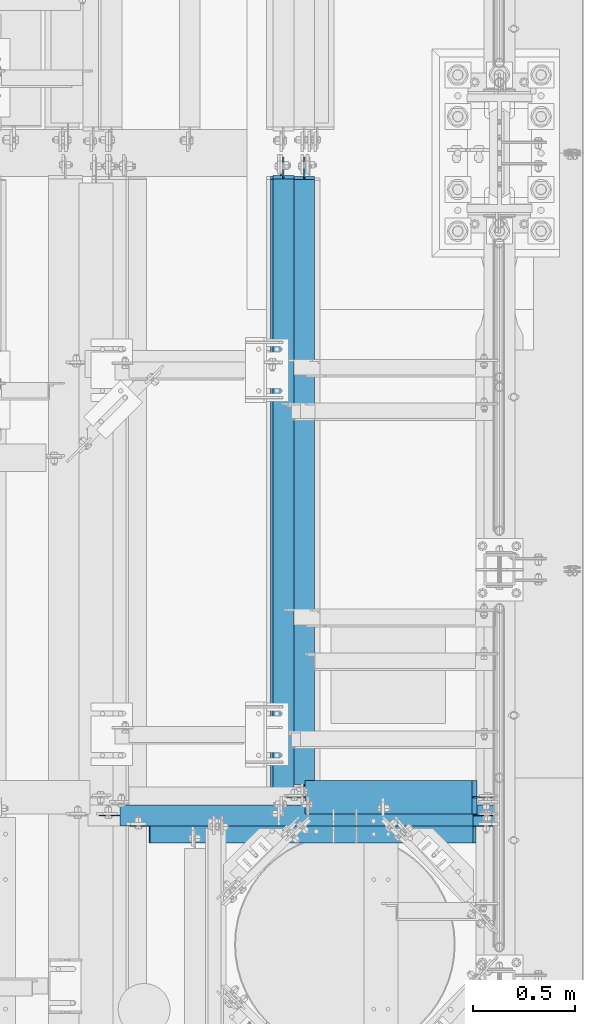
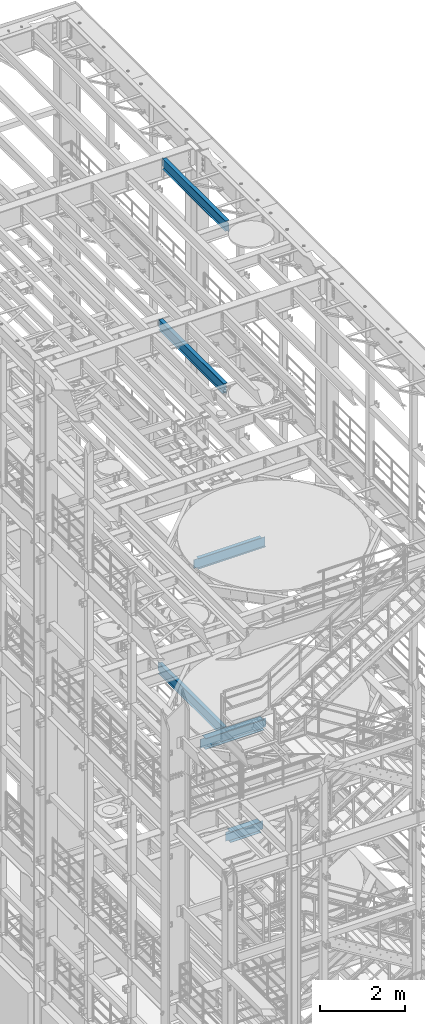
# One storey, part 1033 of 1876: 6 beams, 6 elements without a shape of their own.
"""IFC2X3 building model written with IfcOpenShell, lengths in millimetres."""

from ifc_helpers import new_model, si_unit, frame, origin_with_axes, place, context, subcontext, project, spatial, faceted_brep, material, type_object, element, aggregate, save


model = new_model("IFC2X3")

# Units and contexts
model_context = context("Model", 3, precision=1e-05, world=origin_with_axes())
body_context = subcontext(model_context, "Body", "Model", "MODEL_VIEW")
ifc_project = project(units=[si_unit("LENGTHUNIT", "METRE", prefix="MILLI"), si_unit("AREAUNIT", "SQUARE_METRE"), si_unit("VOLUMEUNIT", "CUBIC_METRE"), si_unit("MASSUNIT", "GRAM", prefix="KILO"), si_unit("TIMEUNIT", "SECOND"), si_unit("PLANEANGLEUNIT", "RADIAN"), si_unit("SOLIDANGLEUNIT", "STERADIAN"), si_unit("THERMODYNAMICTEMPERATUREUNIT", "DEGREE_CELSIUS"), si_unit("LUMINOUSINTENSITYUNIT", "LUMEN")], contexts=[model_context])

# Site, building, storey
site_placement = place(None, origin_with_axes())
site = spatial("IfcSite", under=ifc_project, at=site_placement, CompositionType="ELEMENT")
building_placement = place(site_placement, origin_with_axes())
building = spatial("IfcBuilding", under=site, at=building_placement, Name="Undefined", CompositionType="ELEMENT")
storey_placement = place(building_placement, origin_with_axes())
storey = spatial("IfcBuildingStorey", under=building, at=storey_placement, Name="Undefined", CompositionType="ELEMENT", Elevation=0.0)

# Assembly, beam
assembly_1_placement = place(storey_placement, origin_with_axes())
assembly_1 = element("IfcElementAssembly", 1, at=assembly_1_placement, inside=storey, Name="BEAM", AssemblyPlace="NOTDEFINED", PredefinedType="RIGID_FRAME")
ifc_material = material(Name="STEEL/A992")
beam_type_1 = type_object("IfcBeamType", Name="W12X26", PredefinedType="NOTDEFINED")
beam_1_placement = place(assembly_1_placement, frame((6565.9, 4476.75, 4975.225), z_axis=(0.0, 0.0, 1.0), x_axis=(1.0, 0.0, 0.0)))
beam_1 = element("IfcBeam", 2, at=beam_1_placement, type_object=beam_type_1, material=ifc_material, Name="BEAM", ObjectType="W12X26", context=body_context, shape_type="Brep", body=[
    faceted_brep([(945.356250000002, -3.17500000000018, -146.05), (945.356250000002, -82.5500000000002, -146.05), (945.356250000002, -82.5500000000002, -155.575), (945.356250000002, 82.5500000000002, -155.575), (945.356250000002, 82.5500000000002, -146.05), (945.356250000002, 3.17500000000018, -146.05), (945.356250000002, 3.17500000000018, -142.874999809265), (945.356250000002, -3.17500000000018, -142.874999809265), (946.322979922589, 3.17500000000018, -138.01492029122), (946.322979922589, -3.17500000000018, -138.01492029122), (949.075993823068, 3.17500000000018, -133.894743823066), (949.075993823068, -3.17500000000018, -133.894743823066), (953.196170291221, 3.17500000000018, -131.141729922588), (953.196170291221, -3.17500000000018, -131.141729922588), (958.056249809267, 3.17500000000018, -130.175), (958.056249809267, -3.17500000000018, -130.175), (1034.25625, -3.17500000000018, -130.175), (1034.25625, 3.17500000000018, -130.175), (104.774999999999, 3.17499999999927, 146.05), (104.774999999999, 82.5499999999993, 146.05), (919.956250000002, 82.5500000000002, 146.05), (919.956250000002, 3.17500000000018, 146.05), (104.775000000001, -3.17500000000018, -142.874999809264), (104.775000000001, 3.17500000000018, -142.874999809264), (104.774999924721, 3.17500000000018, -146.049999999999), (104.775000000001, 82.5500000000002, -146.05), (104.775000000001, 82.5500000000002, -155.575), (104.775000000001, -82.5500000000002, -155.575), (104.775000000001, -82.5500000000002, -146.05), (104.774999924721, -3.17500000000018, -146.049999999999), (103.808270077414, -3.17500000000018, -138.014920291219), (103.808270077414, 3.17500000000018, -138.014920291219), (101.055256176935, -3.17500000000018, -133.894743823065), (101.055256176935, 3.17500000000018, -133.894743823065), (96.9350797087818, -3.17500000000018, -131.141729922587), (96.9350797087818, 3.17500000000018, -131.141729922587), (92.0750001907363, -3.17500000000018, -130.174999999999), (92.0750001907363, 3.17500000000018, -130.174999999999), (15.875, -3.17500000000018, -130.175000000003), (15.875, 3.17500000000018, -130.175000000003), (15.8750000000018, -3.17500000000018, 130.175000000001), (15.8750000000018, 3.17500000000018, 130.175000000001), (92.0750001907363, -3.17500000000018, 130.175000000001), (92.0750001907363, 3.17500000000018, 130.175000000001), (96.9350797087818, -3.17500000000018, 131.141729922589), (96.9350797087818, 3.17500000000018, 131.141729922589), (101.055256176935, -3.17500000000018, 133.894743823067), (101.055256176935, 3.17500000000018, 133.894743823067), (103.808270077414, -3.17500000000018, 138.014920291221), (103.808270077414, 3.17500000000018, 138.014920291221), (104.775000000001, -3.17500000000018, 142.874999809266), (104.775000000001, 3.17500000000018, 142.874999809266), (104.774999999999, -82.5499999999993, 155.575), (104.774999999999, 82.5499999999993, 155.575), (104.774999999999, -3.17499999999927, 146.05), (104.774999999999, -82.5499999999993, 146.05), (919.956250000002, -3.17500000000018, 146.05), (919.956250000002, -82.5500000000002, 146.05), (919.956250000002, -82.5500000000002, 155.575), (919.956250000002, 82.5500000000002, 155.575), (919.956250000002, -3.17500000000018, 130.174999809265), (919.956250000002, 3.17500000000018, 130.174999809265), (920.92297992259, -3.17500000000018, 125.314920291219), (920.92297992259, 3.17500000000018, 125.314920291219), (923.675993823068, -3.17500000000018, 121.194743823065), (923.675993823068, 3.17500000000018, 121.194743823065), (927.796170291222, -3.17500000000018, 118.441729922587), (927.796170291222, 3.17500000000018, 118.441729922587), (932.656249809267, -3.17500000000018, 117.474999999999), (932.656249809267, 3.17500000000018, 117.474999999999), (1034.25625, -3.17500000000018, 117.474999999999), (1034.25625, 3.17500000000018, 117.474999999999)], [[[0, 1, 2, 3, 4, 5, 6, 7]], [[7, 6, 8, 9]], [[9, 8, 10, 11]], [[11, 10, 12, 13]], [[13, 12, 14, 15]], [[16, 15, 14, 17]], [[18, 19, 20, 21]], [[22, 23, 24, 25, 26, 27, 28, 29]], [[30, 31, 23, 22]], [[32, 33, 31, 30]], [[34, 35, 33, 32]], [[36, 37, 35, 34]], [[38, 39, 37, 36]], [[40, 41, 39, 38]], [[42, 43, 41, 40]], [[44, 45, 43, 42]], [[46, 47, 45, 44]], [[48, 49, 47, 46]], [[50, 51, 49, 48]], [[52, 53, 19, 18, 51, 50, 54, 55]], [[55, 54, 56, 57]], [[52, 55, 57, 58]], [[53, 52, 58, 59]], [[19, 53, 59, 20]], [[58, 57, 56, 60, 61, 21, 20, 59]], [[62, 63, 61, 60]], [[64, 65, 63, 62]], [[66, 67, 65, 64]], [[68, 69, 67, 66]], [[70, 71, 69, 68]], [[71, 70, 16, 17]], [[12, 10, 8, 6, 5, 24, 23, 31, 33, 35, 37, 39, 41, 43, 45, 47, 49, 51, 18, 21, 61, 63, 65, 67, 69, 71, 17, 14]], [[25, 24, 5, 4]], [[26, 25, 4, 3]], [[27, 26, 3, 2]], [[28, 27, 2, 1]], [[29, 28, 1, 0]], [[70, 68, 66, 64, 62, 60, 56, 54, 50, 48, 46, 44, 42, 40, 38, 36, 34, 32, 30, 22, 29, 0, 7, 9, 11, 13, 15, 16]]]),
])
aggregate(assembly_1, [beam_1])

assembly_2_placement = place(storey_placement, origin_with_axes())
assembly_2 = element("IfcElementAssembly", 3, at=assembly_2_placement, inside=storey, Name="BEAM", AssemblyPlace="NOTDEFINED", PredefinedType="RIGID_FRAME")
beam_type_2 = type_object("IfcBeamType", Name="W12X16", PredefinedType="NOTDEFINED")
beam_2_placement = place(assembly_2_placement, frame((6667.5, 4444.99920043945, 22402.8), z_axis=(0.0, 0.0, 1.0), x_axis=(0.0, 1.0, 0.0)))
beam_2 = element("IfcBeam", 4, at=beam_2_placement, type_object=beam_type_2, material=ifc_material, Name="BEAM", ObjectType="W12X16", context=body_context, shape_type="Brep", body=[
    faceted_brep([(15.8749999999982, -3.17500000000018, -127.0), (15.8749999999982, 3.17500000000018, -127.0), (98.425000190733, 3.17500000000018, -127.0), (98.425000190733, -3.17500000000018, -127.0), (103.285079708779, 3.17500000000018, -127.966729922588), (103.285079708779, -3.17500000000018, -127.966729922588), (107.405256176932, 3.17500000000018, -130.719743823065), (107.405256176932, -3.17500000000018, -130.719743823065), (110.158270077411, 3.17500000000018, -134.839920291219), (110.158270077411, -3.17500000000018, -134.839920291219), (111.124999999998, -3.17500000000018, -139.699999809265), (111.124999999998, 3.17500000000018, -139.699999809265), (111.124999999998, 3.17500000000018, -146.049999999999), (111.124999999998, 50.8000000000002, -146.049999999999), (111.124999999998, 50.8000000000002, -152.400000000001), (111.124999999998, -50.8000000000002, -152.400000000001), (111.124999999998, -50.8000000000002, -146.049999999999), (111.124999999998, -3.17500000000018, -146.049999999999), (3047.20704956055, 50.8000000000002, 146.049999999999), (3047.20704956055, 3.17500000000018, 146.049999999999), (95.2499999999982, 3.17500000000018, 146.049999999999), (95.2499999999982, 50.8000000000002, 146.049999999999), (82.550000190733, -3.17500000000018, 114.299999999999), (82.550000190733, 3.17500000000018, 114.299999999999), (15.8749999999982, 3.17500000000018, 114.299999999999), (15.8749999999982, -3.17500000000018, 114.299999999999), (87.4100797087785, -3.17500000000018, 115.266729922587), (87.4100797087785, 3.17500000000018, 115.266729922587), (91.5302561769322, -3.17500000000018, 118.019743823064), (91.5302561769322, 3.17500000000018, 118.019743823064), (94.2832700774106, -3.17500000000018, 122.139920291218), (94.2832700774106, 3.17500000000018, 122.139920291218), (95.2499999999982, -3.17500000000018, 126.999999809264), (95.2499999999982, 3.17500000000018, 126.999999809264), (3047.20704956055, -50.8000000000002, 152.400000000001), (3047.20704956055, 50.8000000000002, 152.400000000001), (95.2499999999982, 50.8000000000002, 152.400000000001), (95.2499999999982, -50.8000000000002, 152.400000000001), (3047.20704956055, -50.8000000000002, 146.049999999999), (95.2499999999982, -50.8000000000002, 146.049999999999), (3047.20704956055, -3.17500000000018, 146.049999999999), (95.2499999999982, -3.17500000000018, 146.049999999999), (3047.20704956055, -3.17500000000018, 126.999999809268), (3047.20704956055, 3.17500000000018, 126.999999809268), (3048.17377948314, -3.17500000000018, 122.139920291222), (3048.17377948314, 3.17500000000018, 122.139920291222), (3050.92679338361, -3.17500000000018, 118.019743823068), (3050.92679338361, 3.17500000000018, 118.019743823068), (3055.04696985177, -3.17500000000018, 115.26672992259), (3055.04696985177, 3.17500000000018, 115.26672992259), (3059.90704936981, -3.17500000000018, 114.300000000003), (3059.90704936981, 3.17500000000018, 114.300000000003), (3155.15704956055, -3.17500000000018, 114.300000000003), (3155.15704956055, 3.17500000000018, 114.300000000003), (3155.15704956055, -3.17500000000018, -126.999999999996), (3155.15704956055, 3.17500000000018, -126.999999999996), (3072.60704936981, -3.17500000000018, -126.999999999996), (3072.60704936981, 3.17500000000018, -126.999999999996), (3067.74696985177, -3.17500000000018, -127.966729922584), (3067.74696985177, 3.17500000000018, -127.966729922584), (3063.62679338361, -3.17500000000018, -130.719743823061), (3063.62679338361, 3.17500000000018, -130.719743823061), (3060.87377948313, -3.17500000000018, -134.839920291215), (3060.87377948313, 3.17500000000018, -134.839920291215), (3059.90704956055, -3.17500000000018, -139.699999809261), (3059.90704956055, 3.17500000000018, -139.699999809261), (3059.90704956055, -3.17500000000018, -146.049999999999), (3059.90704956055, -50.8000000000002, -146.049999999999), (3059.90704956055, -50.8000000000002, -152.400000000001), (3059.90704956055, 50.8000000000002, -152.400000000001), (3059.90704956055, 50.8000000000002, -146.049999999999), (3059.90704956055, 3.17500000000018, -146.049999999999)], [[[0, 1, 2, 3]], [[3, 2, 4, 5]], [[5, 4, 6, 7]], [[7, 6, 8, 9]], [[10, 11, 12, 13, 14, 15, 16, 17]], [[9, 8, 11, 10]], [[18, 19, 20, 21]], [[22, 23, 24, 25]], [[26, 27, 23, 22]], [[28, 29, 27, 26]], [[30, 31, 29, 28]], [[32, 33, 31, 30]], [[34, 35, 36, 37]], [[38, 34, 37, 39]], [[40, 38, 39, 41]], [[37, 36, 21, 20, 33, 32, 41, 39]], [[35, 18, 21, 36]], [[34, 38, 40, 42, 43, 19, 18, 35]], [[44, 45, 43, 42]], [[46, 47, 45, 44]], [[48, 49, 47, 46]], [[50, 51, 49, 48]], [[52, 53, 51, 50]], [[53, 52, 54, 55]], [[54, 56, 57, 55]], [[58, 59, 57, 56]], [[60, 61, 59, 58]], [[62, 63, 61, 60]], [[64, 65, 63, 62]], [[66, 67, 68, 69, 70, 71, 65, 64]], [[67, 66, 17, 16]], [[68, 67, 16, 15]], [[69, 68, 15, 14]], [[70, 69, 14, 13]], [[71, 70, 13, 12]], [[6, 4, 2, 1, 24, 23, 27, 29, 31, 33, 20, 19, 43, 45, 47, 49, 51, 53, 55, 57, 59, 61, 63, 65, 71, 12, 11, 8]], [[25, 24, 1, 0]], [[66, 64, 62, 60, 58, 56, 54, 52, 50, 48, 46, 44, 42, 40, 41, 32, 30, 28, 26, 22, 25, 0, 3, 5, 7, 9, 10, 17]]]),
])
aggregate(assembly_2, [beam_2])

assembly_3_placement = place(storey_placement, origin_with_axes())
assembly_3 = element("IfcElementAssembly", 5, at=assembly_3_placement, inside=storey, Name="BEAM", AssemblyPlace="NOTDEFINED", PredefinedType="RIGID_FRAME")
beam_3_placement = place(assembly_3_placement, frame((6565.90000011396, 4387.85000007528, 17830.8), z_axis=(0.0, 0.0, 1.0), x_axis=(0.0, 1.0, 0.0)))
beam_3 = element("IfcBeam", 6, at=beam_3_placement, type_object=beam_type_2, material=ifc_material, Name="BEAM", ObjectType="W12X16", context=body_context, shape_type="Brep", body=[
    faceted_brep([(15.8749999999982, -3.17500000000018, -127.0), (15.8749999999982, 3.17500000000018, -127.0), (92.0750001154556, 3.17500000000018, -126.999999999996), (92.0750001154556, -3.17500000000018, -126.999999999996), (96.9350796335011, 3.17500000000018, -127.966729922584), (96.9350796335011, -3.17500000000018, -127.966729922584), (101.055256101655, 3.17500000000018, -130.719743823061), (101.055256101655, -3.17500000000018, -130.719743823061), (103.808270002133, 3.17500000000018, -134.839920291215), (103.808270002133, -3.17500000000018, -134.839920291215), (104.774999924721, -3.17500000000018, -139.699999809261), (104.774999924721, 3.17500000000018, -139.699999809261), (104.774999924721, 3.17500000000018, -146.049999999999), (104.774999924721, 50.8000000000002, -146.049999999999), (104.774999924721, 50.8000000000002, -152.400000000001), (104.774999924721, -50.8000000000002, -152.400000000001), (104.774999924721, -50.8000000000002, -146.049999999999), (104.774999924721, -3.17500000000018, -146.049999999999), (3105.94374992472, 50.8000000000002, 146.049999999999), (3105.94374992472, 3.17500000000018, 146.049999999999), (63.5000000000009, 3.17499999999927, 146.049999999999), (63.4999999247211, 50.8000000000002, 146.049999999999), (50.800000115456, -3.17500000000018, 127.000000000004), (50.800000115456, 3.17500000000018, 127.000000000004), (15.875, 3.17500000000018, 127.000000000001), (15.875, -3.17500000000018, 127.000000000001), (55.6600796335015, -3.17500000000018, 127.966729922591), (55.6600796335015, 3.17500000000018, 127.966729922591), (59.7802561016551, -3.17500000000018, 130.719743823069), (59.7802561016551, 3.17500000000018, 130.719743823069), (62.5332700021336, -3.17500000000018, 134.839920291222), (62.5332700021336, 3.17500000000018, 134.839920291222), (63.4999999247211, -3.17500000000018, 139.699999809269), (63.4999999247211, 3.17500000000018, 139.699999809269), (3105.94374992472, -50.8000000000002, 152.400000000001), (3105.94374992472, 50.8000000000002, 152.400000000001), (63.4999999247211, 50.8000000000002, 152.400000000001), (63.4999999247211, -50.8000000000002, 152.400000000001), (3105.94374992472, -50.8000000000002, 146.049999999999), (63.4999999247211, -50.8000000000002, 146.049999999999), (3105.94374992472, -3.17500000000018, 146.049999999999), (63.5000000000009, -3.17499999999927, 146.049999999999), (3105.94374992472, -3.17500000000018, 120.64999980927), (3105.94374992472, 3.17500000000018, 120.64999980927), (3106.91047984731, -3.17500000000018, 115.789920291223), (3106.91047984731, 3.17500000000018, 115.789920291223), (3109.66349374778, -3.17500000000018, 111.669743823069), (3109.66349374778, 3.17500000000018, 111.669743823069), (3113.78367021594, -3.17500000000018, 108.916729922592), (3113.78367021594, 3.17500000000018, 108.916729922592), (3118.64374973398, -3.17500000000018, 107.950000000004), (3118.64374973398, 3.17500000000018, 107.950000000004), (3212.30624992472, -3.17500000000018, 107.950000000004), (3212.30624992472, 3.17500000000018, 107.950000000004), (3212.30624992472, -3.17500000000018, -126.999999999996), (3212.30624992472, 3.17500000000018, -126.999999999996), (3136.10624973398, -3.17500000000018, -126.999999999996), (3136.10624973398, 3.17500000000018, -126.999999999996), (3131.24617021594, -3.17500000000018, -127.966729922584), (3131.24617021594, 3.17500000000018, -127.966729922584), (3127.12599374778, -3.17500000000018, -130.719743823061), (3127.12599374778, 3.17500000000018, -130.719743823061), (3124.37297984731, -3.17500000000018, -134.839920291215), (3124.37297984731, 3.17500000000018, -134.839920291215), (3123.40624992472, -3.17500000000018, -139.699999809261), (3123.40624992472, 3.17500000000018, -139.699999809261), (3123.40624992472, -3.17500000000018, -146.049999999999), (3123.40624992472, -50.8000000000002, -146.049999999999), (3123.40624992472, -50.8000000000002, -152.400000000001), (3123.40624992472, 50.8000000000002, -152.400000000001), (3123.40624992472, 50.8000000000002, -146.049999999999), (3123.40624992472, 3.17500000000018, -146.049999999999)], [[[0, 1, 2, 3]], [[3, 2, 4, 5]], [[5, 4, 6, 7]], [[7, 6, 8, 9]], [[10, 11, 12, 13, 14, 15, 16, 17]], [[9, 8, 11, 10]], [[18, 19, 20, 21]], [[22, 23, 24, 25]], [[26, 27, 23, 22]], [[28, 29, 27, 26]], [[30, 31, 29, 28]], [[32, 33, 31, 30]], [[34, 35, 36, 37]], [[38, 34, 37, 39]], [[40, 38, 39, 41]], [[37, 36, 21, 20, 33, 32, 41, 39]], [[35, 18, 21, 36]], [[34, 38, 40, 42, 43, 19, 18, 35]], [[44, 45, 43, 42]], [[46, 47, 45, 44]], [[48, 49, 47, 46]], [[50, 51, 49, 48]], [[52, 53, 51, 50]], [[53, 52, 54, 55]], [[54, 56, 57, 55]], [[58, 59, 57, 56]], [[60, 61, 59, 58]], [[62, 63, 61, 60]], [[64, 65, 63, 62]], [[66, 67, 68, 69, 70, 71, 65, 64]], [[67, 66, 17, 16]], [[68, 67, 16, 15]], [[69, 68, 15, 14]], [[70, 69, 14, 13]], [[71, 70, 13, 12]], [[6, 4, 2, 1, 24, 23, 27, 29, 31, 33, 20, 19, 43, 45, 47, 49, 51, 53, 55, 57, 59, 61, 63, 65, 71, 12, 11, 8]], [[25, 24, 1, 0]], [[66, 64, 62, 60, 58, 56, 54, 52, 50, 48, 46, 44, 42, 40, 41, 32, 30, 28, 26, 22, 25, 0, 3, 5, 7, 9, 10, 17]]]),
])
aggregate(assembly_3, [beam_3])

assembly_4_placement = place(storey_placement, origin_with_axes())
assembly_4 = element("IfcElementAssembly", 7, at=assembly_4_placement, inside=storey, Name="BEAM", AssemblyPlace="NOTDEFINED", PredefinedType="RIGID_FRAME")
beam_4_placement = place(assembly_4_placement, frame((5651.5, 4387.85, 13157.2), z_axis=(0.0, 0.0, 1.0), x_axis=(1.0, 0.0, 0.0)))
beam_4 = element("IfcBeam", 8, at=beam_4_placement, type_object=beam_type_2, material=ifc_material, Name="BEAM", ObjectType="W12X16", context=body_context, shape_type="Brep", body=[
    faceted_brep([(1840.70625305176, -50.8000000000002, 152.4), (1840.70625305176, -50.8000000000002, 146.049999999999), (1840.70625305176, -3.17500000000018, 146.049999999999), (1840.70625305176, -3.17500000000018, 126.999999809264), (1840.70625305176, 3.17500000000018, 126.999999809264), (1840.70625305176, 3.17500000000018, 146.049999999999), (1840.70625305176, 50.8000000000002, 146.049999999999), (1840.70625305176, 50.8000000000002, 152.4), (1841.67298297434, -3.17500000000018, 122.139920291218), (1841.67298297434, 3.17500000000018, 122.139920291218), (1844.42599687482, -3.17500000000018, 118.019743823064), (1844.42599687482, 3.17500000000018, 118.019743823064), (1848.54617334297, -3.17500000000018, 115.266729922587), (1848.54617334297, 3.17500000000018, 115.266729922587), (1853.40625286102, -3.17500000000018, 114.299999999999), (1853.40625286102, 3.17500000000018, 114.299999999999), (1948.65625, -3.17500000000018, 114.299999999999), (1948.65625, 3.17500000000018, 114.299999999999), (117.475, -50.8000000000002, 152.4), (117.475, 50.8000000000002, 152.4), (117.475, 50.8000000000002, 146.049999999999), (117.475, 3.17500000000018, 146.049999999999), (117.475, 3.17500000000018, 139.699999809265), (117.475, -3.17500000000018, 139.699999809265), (117.475, -3.17500000000018, 146.049999999999), (117.475, -50.8000000000002, 146.049999999999), (116.508270077413, 3.17500000000018, 134.839920291219), (116.508270077413, -3.17500000000018, 134.839920291219), (113.755256176934, 3.17500000000018, 130.719743823065), (113.755256176934, -3.17500000000018, 130.719743823065), (109.635079708781, 3.17500000000018, 127.966729922588), (109.635079708781, -3.17500000000018, 127.966729922588), (104.775000190735, 3.17500000000018, 127.0), (104.775000190735, -3.17500000000018, 127.0), (15.875, 3.17500000000018, 127.000000000001), (15.875, -3.17500000000018, 127.000000000001), (15.8749999999982, 3.17500000000018, -127.0), (15.8749999999982, -3.17500000000018, -127.0), (104.775000190735, 3.17500000000018, -127.0), (104.775000190735, -3.17500000000018, -127.0), (109.635079708781, 3.17500000000018, -127.966729922588), (109.635079708781, -3.17500000000018, -127.966729922588), (113.755256176934, 3.17500000000018, -130.719743823065), (113.755256176934, -3.17500000000018, -130.719743823065), (116.508270077413, 3.17500000000018, -134.839920291219), (116.508270077413, -3.17500000000018, -134.839920291219), (117.475, 3.17500000000018, -139.699999809265), (117.475, -3.17500000000018, -139.699999809265), (1948.65625, 3.17500000000018, -146.049999999999), (1948.65625, 50.8000000000002, -146.049999999999), (117.475, 50.8000000000002, -146.049999999999), (117.475, 3.17500000000018, -146.049999999999), (1948.65625, 50.8000000000002, -152.4), (117.475, 50.8000000000002, -152.4), (1948.65625, -50.8000000000002, -152.4), (117.475, -50.8000000000002, -152.4), (1948.65625, -50.8000000000002, -146.049999999999), (117.475, -50.8000000000002, -146.049999999999), (117.475, -3.17500000000018, -146.049999999999), (1948.65625, -3.17500000000018, -146.049999999999)], [[[0, 1, 2, 3, 4, 5, 6, 7]], [[8, 9, 4, 3]], [[10, 11, 9, 8]], [[12, 13, 11, 10]], [[14, 15, 13, 12]], [[16, 17, 15, 14]], [[18, 19, 20, 21, 22, 23, 24, 25]], [[23, 22, 26, 27]], [[27, 26, 28, 29]], [[29, 28, 30, 31]], [[31, 30, 32, 33]], [[33, 32, 34, 35]], [[35, 34, 36, 37]], [[37, 36, 38, 39]], [[39, 38, 40, 41]], [[41, 40, 42, 43]], [[43, 42, 44, 45]], [[45, 44, 46, 47]], [[48, 49, 50, 51]], [[49, 52, 53, 50]], [[52, 54, 55, 53]], [[54, 56, 57, 55]], [[47, 46, 51, 50, 53, 55, 57, 58]], [[56, 59, 58, 57]], [[12, 10, 8, 3, 2, 24, 23, 27, 29, 31, 33, 35, 37, 39, 41, 43, 45, 47, 58, 59, 16, 14]], [[25, 24, 2, 1]], [[18, 25, 1, 0]], [[19, 18, 0, 7]], [[20, 19, 7, 6]], [[21, 20, 6, 5]], [[48, 51, 46, 44, 42, 40, 38, 36, 34, 32, 30, 28, 26, 22, 21, 5, 4, 9, 11, 13, 15, 17]], [[59, 56, 54, 52, 49, 48, 17, 16]]]),
])
aggregate(assembly_4, [beam_4])

assembly_5_placement = place(storey_placement, origin_with_axes())
assembly_5 = element("IfcElementAssembly", 9, at=assembly_5_placement, inside=storey, Name="BEAM", AssemblyPlace="NOTDEFINED", PredefinedType="RIGID_FRAME")
beam_5_placement = place(assembly_5_placement, frame((6553.2, 4324.35, 8001.0), z_axis=(0.0, 0.0, 1.0), x_axis=(0.0, 1.0, 0.0)))
beam_5 = element("IfcBeam", 10, at=beam_5_placement, type_object=beam_type_2, material=ifc_material, Name="BEAM", ObjectType="W12X16", context=body_context, shape_type="Brep", body=[
    faceted_brep([(3180.55625, -3.17500000000018, -146.05), (3180.55625, -50.8000000000002, -146.05), (3180.55625, -50.8000000000002, -152.4), (3180.55625, 50.8000000000002, -152.4), (3180.55625, 50.8000000000002, -146.05), (3180.55625, 3.17500000000018, -146.05), (3180.55625, 3.17500000000018, -139.699999809266), (3180.55625, -3.17500000000018, -139.699999809266), (3181.52297992259, 3.17500000000018, -134.839920291221), (3181.52297992259, -3.17500000000018, -134.839920291221), (3184.27599382307, 3.17500000000018, -130.719743823067), (3184.27599382307, -3.17500000000018, -130.719743823067), (3188.39617029122, 3.17500000000018, -127.966729922588), (3188.39617029122, -3.17500000000018, -127.966729922588), (3193.25624980926, 3.17500000000018, -127.000000000001), (3193.25624980926, -3.17500000000018, -127.000000000001), (3275.80625, -3.17500000000018, -127.000000000001), (3275.80625, 3.17500000000018, -127.000000000001), (123.824999999999, 3.17500000000018, 146.05), (123.824999999999, 50.8000000000002, 146.05), (3167.85625, 50.8000000000002, 146.05), (3167.85625, 3.17500000000018, 146.05), (123.824999999999, -3.17500000000018, -139.699999809264), (123.824999999999, 3.17500000000018, -139.699999809264), (123.824999999999, 3.17500000000018, -146.05), (123.824999999999, 50.8000000000002, -146.05), (123.824999999999, 50.8000000000002, -152.4), (123.824999999999, -50.8000000000002, -152.4), (123.824999999999, -50.8000000000002, -146.05), (123.824999999999, -3.17500000000018, -146.05), (122.858270077411, -3.17500000000018, -134.839920291219), (122.858270077411, 3.17500000000018, -134.839920291219), (120.105256176933, -3.17500000000018, -130.719743823065), (120.105256176933, 3.17500000000018, -130.719743823065), (115.985079708779, -3.17500000000018, -127.966729922587), (115.985079708779, 3.17500000000018, -127.966729922587), (111.125000190734, -3.17500000000018, -126.999999999999), (111.125000190734, 3.17500000000018, -126.999999999999), (28.5749999999989, -3.17500000000018, -126.999999999999), (28.5749999999989, 3.17500000000018, -126.999999999999), (28.5749999999989, -3.17500000000018, 127.000000000001), (28.5749999999989, 3.17500000000018, 127.000000000001), (111.125000190734, -3.17500000000018, 127.000000000001), (111.125000190734, 3.17500000000018, 127.000000000001), (115.985079708779, -3.17500000000018, 127.966729922588), (115.985079708779, 3.17500000000018, 127.966729922588), (120.105256176933, -3.17500000000018, 130.719743823067), (120.105256176933, 3.17500000000018, 130.719743823067), (122.858270077411, -3.17500000000018, 134.839920291221), (122.858270077411, 3.17500000000018, 134.839920291221), (123.824999999999, -3.17500000000018, 139.699999809266), (123.824999999999, 3.17500000000018, 139.699999809266), (123.824999999999, -50.8000000000002, 152.4), (123.824999999999, 50.8000000000002, 152.4), (123.824999999999, -3.17500000000018, 146.05), (123.824999999999, -50.8000000000002, 146.05), (3167.85625, -3.17500000000018, 146.05), (3167.85625, -50.8000000000002, 146.05), (3167.85625, -50.8000000000002, 152.4), (3167.85625, 50.8000000000002, 152.4), (3167.85625, -3.17500000000018, 126.999999809264), (3167.85625, 3.17500000000018, 126.999999809264), (3168.82297992259, -3.17500000000018, 122.139920291219), (3168.82297992259, 3.17500000000018, 122.139920291219), (3171.57599382307, -3.17500000000018, 118.019743823065), (3171.57599382307, 3.17500000000018, 118.019743823065), (3175.69617029122, -3.17500000000018, 115.266729922587), (3175.69617029122, 3.17500000000018, 115.266729922587), (3180.55624980926, -3.17500000000018, 114.299999999999), (3180.55624980926, 3.17500000000018, 114.299999999999), (3275.80625, -3.17500000000018, 114.299999999999), (3275.80625, 3.17500000000018, 114.299999999999)], [[[0, 1, 2, 3, 4, 5, 6, 7]], [[7, 6, 8, 9]], [[9, 8, 10, 11]], [[11, 10, 12, 13]], [[13, 12, 14, 15]], [[16, 15, 14, 17]], [[18, 19, 20, 21]], [[22, 23, 24, 25, 26, 27, 28, 29]], [[30, 31, 23, 22]], [[32, 33, 31, 30]], [[34, 35, 33, 32]], [[36, 37, 35, 34]], [[38, 39, 37, 36]], [[40, 41, 39, 38]], [[42, 43, 41, 40]], [[44, 45, 43, 42]], [[46, 47, 45, 44]], [[48, 49, 47, 46]], [[50, 51, 49, 48]], [[52, 53, 19, 18, 51, 50, 54, 55]], [[55, 54, 56, 57]], [[52, 55, 57, 58]], [[53, 52, 58, 59]], [[19, 53, 59, 20]], [[58, 57, 56, 60, 61, 21, 20, 59]], [[62, 63, 61, 60]], [[64, 65, 63, 62]], [[66, 67, 65, 64]], [[68, 69, 67, 66]], [[70, 71, 69, 68]], [[71, 70, 16, 17]], [[12, 10, 8, 6, 5, 24, 23, 31, 33, 35, 37, 39, 41, 43, 45, 47, 49, 51, 18, 21, 61, 63, 65, 67, 69, 71, 17, 14]], [[25, 24, 5, 4]], [[26, 25, 4, 3]], [[27, 26, 3, 2]], [[28, 27, 2, 1]], [[29, 28, 1, 0]], [[70, 68, 66, 64, 62, 60, 56, 54, 50, 48, 46, 44, 42, 40, 38, 36, 34, 32, 30, 22, 29, 0, 7, 9, 11, 13, 15, 16]]]),
])
aggregate(assembly_5, [beam_5])

assembly_6_placement = place(storey_placement, origin_with_axes())
assembly_6 = element("IfcElementAssembly", 11, at=assembly_6_placement, inside=storey, Name="BEAM", AssemblyPlace="NOTDEFINED", PredefinedType="RIGID_FRAME")
beam_type_3 = type_object("IfcBeamType", Name="W12X30", PredefinedType="NOTDEFINED")
beam_6_placement = place(assembly_6_placement, frame((5645.15, 4337.05, 7996.2375), z_axis=(0.0, 0.0, 1.0), x_axis=(1.0, 0.0, 0.0)))
beam_6 = element("IfcBeam", 12, at=beam_6_placement, type_object=beam_type_3, material=ifc_material, Name="BEAM", ObjectType="W12X30", context=body_context, shape_type="Brep", body=[
    faceted_brep([(169.068749999999, -3.17500000000018, -131.7625), (169.068749999999, 3.17500000000018, -131.7625), (251.618750190735, 3.17500000000018, -131.7625), (251.618750190735, -3.17500000000018, -131.7625), (256.478829708781, 3.17500000000018, -132.729229922587), (256.478829708781, -3.17500000000018, -132.729229922587), (260.599006176934, 3.17500000000018, -135.482243823066), (260.599006176934, -3.17500000000018, -135.482243823066), (263.352020077413, 3.17500000000018, -139.602420291219), (263.352020077413, -3.17500000000018, -139.602420291219), (264.31875, -3.17500000000018, -144.462499809265), (264.31875, 3.17500000000018, -144.462499809265), (264.31875, 3.17500000000018, -146.05), (264.31875, 82.5500000000002, -146.05), (264.31875, 82.5500000000002, -157.1625), (264.31875, -82.5500000000002, -157.1625), (264.31875, -82.5500000000002, -146.05), (264.31875, -3.17500000000018, -146.05), (1847.05625, 82.5500000000002, 146.05), (1847.05625, 3.17500000000018, 146.05), (270.668750000001, 3.17500000000018, 146.05), (270.668750000001, 82.5500000000002, 146.05), (257.968750190736, -3.17500000000018, 125.4125), (257.968750190736, 3.17500000000018, 125.4125), (169.068749999999, 3.17500000000018, 125.4125), (169.068749999999, -3.17500000000018, 125.4125), (262.828829708781, -3.17500000000018, 126.379229922588), (262.828829708781, 3.17500000000018, 126.379229922588), (266.949006176935, -3.17500000000018, 129.132243823066), (266.949006176935, 3.17500000000018, 129.132243823066), (269.702020077413, -3.17500000000018, 133.25242029122), (269.702020077413, 3.17500000000018, 133.25242029122), (270.668750000001, -3.17500000000018, 138.112499809266), (270.668750000001, 3.17500000000018, 138.112499809266), (1847.05625, -82.5500000000002, 157.1625), (1847.05625, 82.5500000000002, 157.1625), (270.668750000001, 82.5500000000002, 157.1625), (270.668750000001, -82.5500000000002, 157.1625), (1847.05625, -82.5500000000002, 146.05), (270.668750000001, -82.5500000000002, 146.05), (1847.05625, -3.17500000000018, 146.05), (270.668750000001, -3.17500000000018, 146.05), (1847.05625, -3.17500000000018, 131.762499809264), (1847.05625, 3.17500000000018, 131.762499809264), (1848.02297992259, -3.17500000000018, 126.902420291219), (1848.02297992259, 3.17500000000018, 126.902420291219), (1850.77599382307, -3.17500000000018, 122.782243823065), (1850.77599382307, 3.17500000000018, 122.782243823065), (1854.89617029122, -3.17500000000018, 120.029229922587), (1854.89617029122, 3.17500000000018, 120.029229922587), (1859.75624980926, -3.17500000000018, 119.062499999999), (1859.75624980926, 3.17500000000018, 119.062499999999), (1955.00625, -3.17500000000018, 119.062499999999), (1955.00625, 3.17500000000018, 119.062499999999), (1955.00625, -3.17500000000018, -131.762500000001), (1955.00625, 3.17500000000018, -131.762500000001), (1872.45624980926, -3.17500000000018, -131.762500000001), (1872.45624980926, 3.17500000000018, -131.762500000001), (1867.59617029122, -3.17500000000018, -132.729229922588), (1867.59617029122, 3.17500000000018, -132.729229922588), (1863.47599382307, -3.17500000000018, -135.482243823067), (1863.47599382307, 3.17500000000018, -135.482243823067), (1860.72297992259, -3.17500000000018, -139.60242029122), (1860.72297992259, 3.17500000000018, -139.60242029122), (1859.75625, -3.17500000000018, -144.462499809266), (1859.75625, 3.17500000000018, -144.462499809266), (1859.75625, -3.17500000000018, -146.05), (1859.75625, -82.5500000000002, -146.05), (1859.75625, -82.5500000000002, -157.1625), (1859.75625, 82.5500000000002, -157.1625), (1859.75625, 82.5500000000002, -146.05), (1859.75625, 3.17500000000018, -146.05)], [[[0, 1, 2, 3]], [[3, 2, 4, 5]], [[5, 4, 6, 7]], [[7, 6, 8, 9]], [[10, 11, 12, 13, 14, 15, 16, 17]], [[9, 8, 11, 10]], [[18, 19, 20, 21]], [[22, 23, 24, 25]], [[26, 27, 23, 22]], [[28, 29, 27, 26]], [[30, 31, 29, 28]], [[32, 33, 31, 30]], [[34, 35, 36, 37]], [[38, 34, 37, 39]], [[40, 38, 39, 41]], [[37, 36, 21, 20, 33, 32, 41, 39]], [[35, 18, 21, 36]], [[34, 38, 40, 42, 43, 19, 18, 35]], [[44, 45, 43, 42]], [[46, 47, 45, 44]], [[48, 49, 47, 46]], [[50, 51, 49, 48]], [[52, 53, 51, 50]], [[53, 52, 54, 55]], [[54, 56, 57, 55]], [[58, 59, 57, 56]], [[60, 61, 59, 58]], [[62, 63, 61, 60]], [[64, 65, 63, 62]], [[66, 67, 68, 69, 70, 71, 65, 64]], [[67, 66, 17, 16]], [[68, 67, 16, 15]], [[69, 68, 15, 14]], [[70, 69, 14, 13]], [[71, 70, 13, 12]], [[6, 4, 2, 1, 24, 23, 27, 29, 31, 33, 20, 19, 43, 45, 47, 49, 51, 53, 55, 57, 59, 61, 63, 65, 71, 12, 11, 8]], [[25, 24, 1, 0]], [[66, 64, 62, 60, 58, 56, 54, 52, 50, 48, 46, 44, 42, 40, 41, 32, 30, 28, 26, 22, 25, 0, 3, 5, 7, 9, 10, 17]]]),
])
aggregate(assembly_6, [beam_6])

save(model, "model.ifc")
